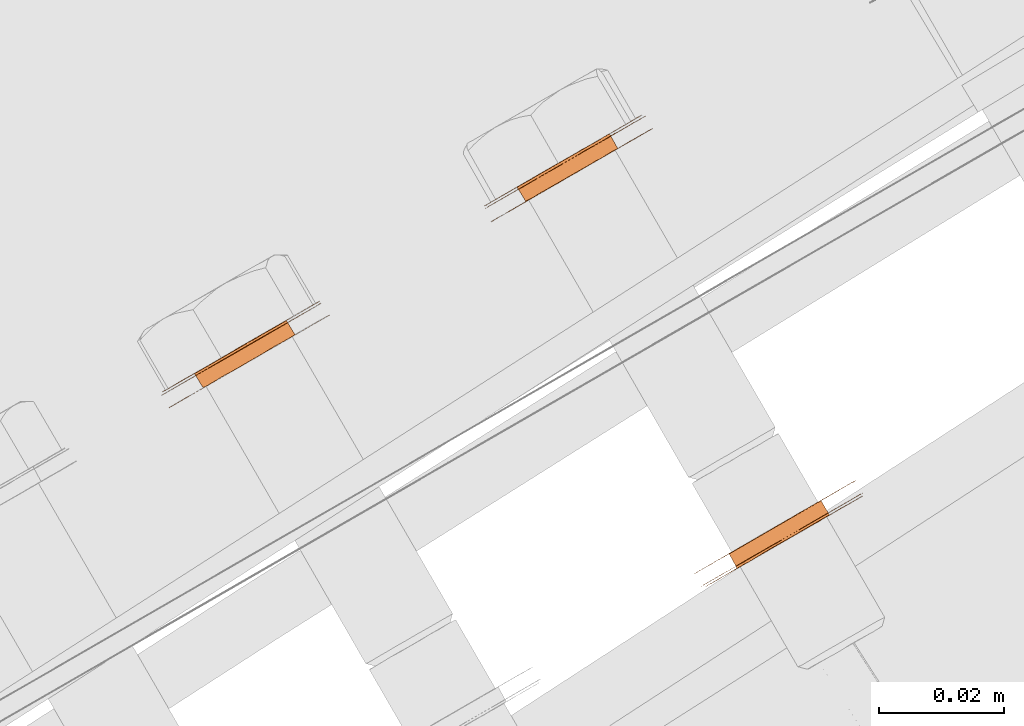
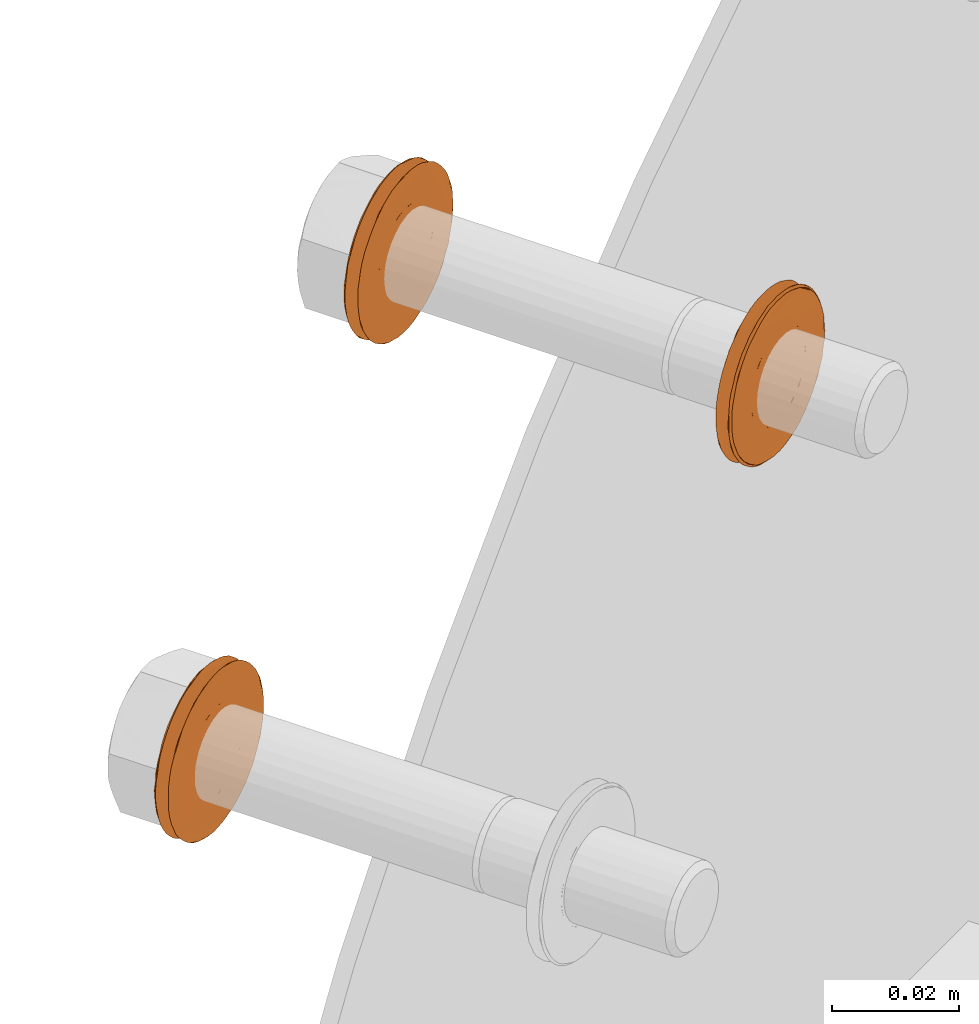
# One storey, part 107 of 126: 3 proxies.
"""IFC2X3 building model written with IfcOpenShell, lengths in millimetres."""

from ifc_helpers import new_model, si_unit, origin, origin_with_axes, place, context, project, spatial, faceted_brep, material, element, save


model = new_model("IFC2X3")

# Units and contexts
context_of_model_1 = context(None, 3, precision=0.1, world=origin())
context_of_model_2 = context(None, 3, precision=0.1, world=origin())
ifc_project = project(units=[si_unit("LENGTHUNIT", "METRE", prefix="MILLI"), si_unit("AREAUNIT", "SQUARE_METRE", prefix="CENTI"), si_unit("VOLUMEUNIT", "CUBIC_METRE", prefix="CENTI"), si_unit("MASSUNIT", "GRAM", prefix="KILO")], contexts=[context_of_model_1, context_of_model_2])

# Site, building, storey
site_placement = place(None, origin_with_axes())
site = spatial("IfcSite", under=ifc_project, at=site_placement, CompositionType="ELEMENT")
building_placement = place(site_placement, origin_with_axes())
building = spatial("IfcBuilding", under=site, at=building_placement, CompositionType="ELEMENT")
storey_placement = place(building_placement, origin_with_axes())
storey = spatial("IfcBuildingStorey", under=building, at=storey_placement, CompositionType="ELEMENT")

# Proxies
ifc_material = material(Name="STAHL")
proxy_1_placement = place(storey_placement, origin_with_axes())
element("IfcBuildingElementProxy", 1, at=proxy_1_placement, inside=storey, material=ifc_material, Name="profile", context=context_of_model_2, shape_type="Brep", body=[
    faceted_brep([(3703.7, 14806.2, 1165.8), (3705.0, 14803.9, 1165.8), (3705.3, 14804.1, 1167.0), (3704.0, 14806.4, 1167.0), (3703.2, 14806.0, 1164.7), (3704.6, 14803.6, 1164.7), (3702.7, 14805.7, 1163.7), (3704.0, 14803.3, 1163.7), (3702.0, 14805.3, 1162.8), (3703.3, 14802.9, 1162.8), (3692.4, 14799.7, 1175.6), (3693.7, 14797.4, 1175.6), (3692.9, 14796.9, 1174.8), (3691.6, 14799.2, 1174.8), (3693.3, 14800.2, 1176.2), (3694.6, 14797.9, 1176.2), (3694.2, 14800.8, 1176.8), (3695.6, 14798.4, 1176.8), (3695.2, 14801.3, 1177.1), (3696.6, 14799.0, 1177.1), (3696.3, 14802.0, 1177.3), (3697.6, 14799.6, 1177.3), (3697.3, 14802.6, 1177.3), (3698.7, 14800.2, 1177.3), (3698.4, 14803.2, 1177.1), (3699.7, 14800.8, 1177.1), (3699.4, 14803.7, 1176.8), (3700.7, 14801.4, 1176.8), (3700.3, 14804.3, 1176.2), (3701.7, 14802.0, 1176.2), (3701.2, 14804.8, 1175.6), (3702.5, 14802.5, 1175.6), (3702.0, 14805.3, 1174.8), (3703.3, 14802.9, 1174.8), (3702.7, 14805.7, 1173.9), (3704.0, 14803.3, 1173.9), (3703.2, 14806.0, 1172.9), (3704.6, 14803.6, 1172.9), (3703.7, 14806.2, 1171.8), (3705.0, 14803.9, 1171.8), (3704.0, 14806.4, 1170.6), (3705.3, 14804.1, 1170.6), (3704.1, 14806.5, 1169.4), (3705.5, 14804.2, 1169.4), (3704.1, 14806.5, 1168.2), (3705.5, 14804.2, 1168.2), (3685.2, 14792.4, 1168.0), (3685.2, 14792.4, 1169.6), (3685.3, 14792.5, 1171.1), (3685.6, 14792.7, 1172.7), (3686.0, 14792.9, 1174.2), (3686.6, 14793.2, 1175.6), (3687.2, 14793.6, 1177.0), (3688.0, 14794.1, 1178.2), (3689.0, 14794.6, 1179.4), (3690.0, 14795.2, 1180.4), (3691.1, 14795.8, 1181.4), (3692.2, 14796.5, 1182.2), (3693.5, 14797.2, 1182.8), (3694.8, 14798.0, 1183.3), (3696.1, 14798.7, 1183.6), (3697.5, 14799.5, 1183.8), (3698.8, 14800.3, 1183.8), (3700.2, 14801.1, 1183.6), (3701.5, 14801.9, 1183.3), (3702.8, 14802.6, 1182.8), (3704.0, 14803.3, 1182.2), (3705.2, 14804.0, 1181.4), (3706.3, 14804.6, 1180.4), (3707.3, 14805.2, 1179.4), (3708.2, 14805.7, 1178.2), (3709.0, 14806.2, 1177.0), (3709.7, 14806.6, 1175.6), (3710.3, 14806.9, 1174.2), (3710.7, 14807.2, 1172.7), (3711.0, 14807.3, 1171.1), (3709.8, 14809.3, 1171.1), (3709.5, 14809.2, 1172.7), (3709.1, 14808.9, 1174.2), (3708.6, 14808.6, 1175.6), (3707.9, 14808.2, 1177.0), (3707.1, 14807.7, 1178.2), (3706.2, 14807.2, 1179.4), (3705.2, 14806.6, 1180.4), (3704.1, 14806.0, 1181.4), (3702.9, 14805.3, 1182.2), (3701.6, 14804.6, 1182.8), (3700.4, 14803.8, 1183.3), (3699.0, 14803.1, 1183.6), (3697.7, 14802.3, 1183.8), (3696.3, 14801.5, 1183.8), (3695.0, 14800.7, 1183.6), (3693.6, 14800.0, 1183.3), (3692.3, 14799.2, 1182.8), (3691.1, 14798.5, 1182.2), (3689.9, 14797.8, 1181.4), (3688.8, 14797.2, 1180.4), (3687.8, 14796.6, 1179.4), (3686.9, 14796.1, 1178.2), (3686.1, 14795.6, 1177.0), (3685.4, 14795.2, 1175.6), (3684.9, 14794.9, 1174.2), (3684.4, 14794.7, 1172.7), (3684.2, 14794.5, 1171.1), (3684.0, 14794.4, 1169.6), (3684.0, 14794.4, 1168.0), (3684.2, 14794.5, 1166.4), (3684.4, 14794.7, 1164.9), (3684.9, 14794.9, 1163.4), (3685.4, 14795.2, 1162.0), (3686.1, 14795.6, 1160.6), (3686.9, 14796.1, 1159.3), (3687.8, 14796.6, 1158.2), (3688.8, 14797.2, 1157.1), (3689.9, 14797.8, 1156.2), (3691.1, 14798.5, 1155.4), (3692.3, 14799.2, 1154.8), (3693.6, 14800.0, 1154.3), (3695.0, 14800.7, 1154.0), (3696.3, 14801.5, 1153.8), (3697.7, 14802.3, 1153.8), (3699.0, 14803.1, 1154.0), (3700.4, 14803.8, 1154.3), (3701.6, 14804.6, 1154.8), (3702.9, 14805.3, 1155.4), (3704.1, 14806.0, 1156.2), (3705.2, 14806.6, 1157.1), (3706.2, 14807.2, 1158.2), (3707.1, 14807.7, 1159.3), (3707.9, 14808.2, 1160.6), (3708.6, 14808.6, 1162.0), (3709.1, 14808.9, 1163.4), (3709.5, 14809.2, 1164.9), (3709.8, 14809.3, 1166.4), (3710.0, 14809.4, 1168.0), (3710.0, 14809.4, 1169.6), (3711.1, 14807.4, 1169.6), (3711.1, 14807.4, 1168.0), (3711.0, 14807.3, 1166.4), (3710.7, 14807.2, 1164.9), (3710.3, 14806.9, 1163.4), (3709.7, 14806.6, 1162.0), (3709.0, 14806.2, 1160.6), (3708.2, 14805.7, 1159.3), (3707.3, 14805.2, 1158.2), (3706.3, 14804.6, 1157.1), (3705.2, 14804.0, 1156.2), (3704.0, 14803.3, 1155.4), (3702.8, 14802.6, 1154.8), (3701.5, 14801.9, 1154.3), (3700.2, 14801.1, 1154.0), (3698.8, 14800.3, 1153.8), (3697.5, 14799.5, 1153.8), (3696.1, 14798.7, 1154.0), (3694.8, 14798.0, 1154.3), (3693.5, 14797.2, 1154.8), (3692.2, 14796.5, 1155.4), (3691.1, 14795.8, 1156.2), (3690.0, 14795.2, 1157.1), (3689.0, 14794.6, 1158.2), (3688.0, 14794.1, 1159.3), (3687.2, 14793.6, 1160.6), (3686.6, 14793.2, 1162.0), (3686.0, 14792.9, 1163.4), (3685.6, 14792.7, 1164.9), (3685.3, 14792.5, 1166.4), (3695.8, 14801.7, 1154.2), (3697.1, 14802.5, 1154.2), (3698.5, 14803.2, 1154.3), (3699.8, 14804.0, 1154.6), (3701.1, 14804.8, 1155.1), (3702.4, 14805.5, 1155.7), (3703.6, 14806.2, 1156.5), (3704.7, 14806.8, 1157.4), (3705.7, 14807.4, 1158.5), (3706.6, 14807.9, 1159.6), (3707.4, 14808.4, 1160.9), (3708.1, 14808.8, 1162.3), (3708.7, 14809.1, 1163.8), (3709.1, 14809.3, 1165.3), (3709.3, 14809.5, 1166.8), (3709.4, 14809.6, 1168.4), (3709.4, 14809.5, 1170.0), (3709.2, 14809.4, 1171.5), (3708.9, 14809.2, 1173.1), (3708.4, 14809.0, 1174.6), (3707.8, 14808.6, 1176.0), (3707.1, 14808.2, 1177.3), (3706.2, 14807.7, 1178.5), (3705.2, 14807.1, 1179.7), (3704.2, 14806.5, 1180.6), (3703.0, 14805.8, 1181.5), (3701.8, 14805.1, 1182.2), (3700.5, 14804.4, 1182.7), (3699.2, 14803.6, 1183.1), (3697.8, 14802.8, 1183.3), (3696.4, 14802.1, 1183.4), (3695.1, 14801.3, 1183.3), (3693.7, 14800.5, 1183.0), (3692.4, 14799.7, 1182.5), (3691.2, 14799.0, 1181.9), (3690.0, 14798.3, 1181.1), (3688.9, 14797.7, 1180.2), (3687.8, 14797.1, 1179.1), (3686.9, 14796.6, 1177.9), (3686.1, 14796.1, 1176.7), (3685.5, 14795.7, 1175.3), (3684.9, 14795.4, 1173.8), (3684.5, 14795.2, 1172.3), (3684.3, 14795.0, 1170.8), (3684.1, 14795.0, 1169.2), (3684.2, 14795.0, 1167.6), (3684.4, 14795.1, 1166.0), (3684.7, 14795.3, 1164.5), (3685.2, 14795.5, 1163.0), (3685.8, 14795.9, 1161.6), (3686.5, 14796.3, 1160.3), (3687.4, 14796.8, 1159.0), (3688.3, 14797.4, 1157.9), (3689.4, 14798.0, 1156.9), (3690.6, 14798.7, 1156.1), (3691.8, 14799.4, 1155.4), (3693.1, 14800.1, 1154.8), (3694.4, 14800.9, 1154.5), (3697.3, 14802.6, 1160.3), (3698.4, 14803.2, 1160.5), (3699.4, 14803.7, 1160.8), (3700.3, 14804.3, 1161.3), (3701.2, 14804.8, 1162.0), (3690.9, 14798.9, 1173.9), (3690.3, 14798.5, 1172.9), (3689.9, 14798.3, 1171.8), (3689.6, 14798.1, 1170.6), (3689.4, 14798.0, 1169.4), (3689.4, 14798.0, 1168.2), (3689.6, 14798.1, 1167.0), (3689.9, 14798.3, 1165.8), (3690.3, 14798.5, 1164.7), (3690.9, 14798.9, 1163.7), (3691.6, 14799.2, 1162.8), (3692.4, 14799.7, 1162.0), (3693.3, 14800.2, 1161.3), (3694.2, 14800.8, 1160.8), (3695.2, 14801.3, 1160.5), (3696.3, 14802.0, 1160.3), (3692.2, 14796.5, 1173.9), (3702.5, 14802.5, 1162.0), (3701.7, 14802.0, 1161.3), (3700.7, 14801.4, 1160.8), (3699.7, 14800.8, 1160.5), (3698.7, 14800.2, 1160.3), (3697.6, 14799.6, 1160.3), (3696.6, 14799.0, 1160.5), (3695.6, 14798.4, 1160.8), (3694.6, 14797.9, 1161.3), (3693.7, 14797.4, 1162.0), (3692.9, 14796.9, 1162.8), (3692.2, 14796.5, 1163.7), (3691.7, 14796.2, 1164.7), (3691.2, 14795.9, 1165.8), (3690.9, 14795.8, 1167.0), (3690.8, 14795.7, 1168.2), (3690.8, 14795.7, 1169.4), (3690.9, 14795.8, 1170.6), (3691.2, 14795.9, 1171.8), (3691.7, 14796.2, 1172.9)], [[[0, 1, 2, 3]], [[4, 5, 1, 0]], [[6, 7, 5, 4]], [[6, 8, 9, 7]], [[10, 11, 12, 13]], [[14, 15, 11, 10]], [[16, 17, 15, 14]], [[18, 19, 17, 16]], [[20, 21, 19, 18]], [[22, 23, 21, 20]], [[24, 25, 23, 22]], [[26, 27, 25, 24]], [[28, 29, 27, 26]], [[30, 31, 29, 28]], [[32, 33, 31, 30]], [[34, 35, 33, 32]], [[36, 37, 35, 34]], [[38, 39, 37, 36]], [[40, 41, 39, 38]], [[42, 43, 41, 40]], [[44, 45, 43, 42]], [[3, 2, 45, 44]], [[46, 47, 48, 49, 50, 51, 52, 53, 54, 55, 56, 57, 58, 59, 60, 61, 62, 63, 64, 65, 66, 67, 68, 69, 70, 71, 72, 73, 74, 75, 76, 77, 78, 79, 80, 81, 82, 83, 84, 85, 86, 87, 88, 89, 90, 91, 92, 93, 94, 95, 96, 97, 98, 99, 100, 101, 102, 103, 104, 105, 106, 107, 108, 109, 110, 111, 112, 113, 114, 115, 116, 117, 118, 119, 120, 121, 122, 123, 124, 125, 126, 127, 128, 129, 130, 131, 132, 133, 134, 135, 76, 75, 136, 137, 138, 139, 140, 141, 142, 143, 144, 145, 146, 147, 148, 149, 150, 151, 152, 153, 154, 155, 156, 157, 158, 159, 160, 161, 162, 163, 164, 165]], [[105, 104, 103, 102, 101, 100, 99, 98, 97, 96, 95, 94, 93, 92, 91, 90, 89, 88, 87, 86, 85, 84, 83, 82, 81, 80, 79, 78, 77, 76, 135, 134, 133, 132, 131, 130, 129, 128, 127, 126, 125, 124, 123, 122, 121, 120, 119, 166, 167, 168, 169, 170, 171, 172, 173, 174, 175, 176, 177, 178, 179, 180, 181, 182, 183, 184, 185, 186, 187, 188, 189, 190, 191, 192, 193, 194, 195, 196, 197, 198, 199, 200, 201, 202, 203, 204, 205, 206, 207, 208, 209, 210, 211, 212, 213, 214, 215, 216, 217, 218, 219, 220, 221, 222, 223, 166, 119, 118, 117, 116, 115, 114, 113, 112, 111, 110, 109, 108, 107, 106]], [[210, 209, 208, 207, 206, 205, 204, 203, 202, 201, 200, 199, 198, 197, 196, 195, 194, 193, 192, 191, 190, 189, 188, 187, 186, 185, 184, 183, 182, 181, 180, 179, 178, 177, 176, 175, 174, 173, 172, 171, 170, 169, 168, 167, 224, 225, 226, 227, 228, 8, 6, 4, 0, 3, 44, 42, 40, 38, 36, 34, 32, 30, 28, 26, 24, 22, 20, 18, 16, 14, 10, 13, 229, 230, 231, 232, 233, 234, 235, 236, 237, 238, 239, 240, 241, 242, 243, 244, 224, 167, 166, 223, 222, 221, 220, 219, 218, 217, 216, 215, 214, 213, 212, 211]], [[229, 13, 12, 245]], [[228, 246, 9, 8]], [[228, 227, 247, 246]], [[227, 226, 248, 247]], [[226, 225, 249, 248]], [[225, 224, 250, 249]], [[224, 244, 251, 250]], [[244, 243, 252, 251]], [[243, 242, 253, 252]], [[242, 241, 254, 253]], [[241, 240, 255, 254]], [[240, 239, 256, 255]], [[239, 238, 257, 256]], [[238, 237, 258, 257]], [[237, 236, 259, 258]], [[236, 235, 260, 259]], [[235, 234, 261, 260]], [[234, 233, 262, 261]], [[233, 232, 263, 262]], [[232, 231, 264, 263]], [[231, 230, 265, 264]], [[230, 229, 245, 265]], [[47, 46, 165, 164, 163, 162, 161, 160, 159, 158, 157, 156, 155, 154, 153, 152, 151, 251, 252, 253, 254, 255, 256, 257, 258, 259, 260, 261, 262, 263, 264, 265, 245, 12, 11, 15, 17, 19, 21, 23, 25, 27, 29, 31, 33, 35, 37, 39, 41, 43, 45, 2, 1, 5, 7, 9, 246, 247, 248, 249, 250, 251, 151, 150, 149, 148, 147, 146, 145, 144, 143, 142, 141, 140, 139, 138, 137, 136, 75, 74, 73, 72, 71, 70, 69, 68, 67, 66, 65, 64, 63, 62, 61, 60, 59, 58, 57, 56, 55, 54, 53, 52, 51, 50, 49, 48]]]),
])
proxy_2_placement = place(storey_placement, origin_with_axes())
element("IfcBuildingElementProxy", 2, at=proxy_2_placement, inside=storey, material=ifc_material, Name="profile", context=context_of_model_2, shape_type="Brep", body=[
    faceted_brep([(3785.8, 14772.4, 1220.3), (3784.5, 14774.7, 1220.3), (3783.4, 14774.1, 1220.0), (3784.8, 14771.8, 1220.0), (3786.8, 14772.9, 1220.7), (3785.4, 14775.3, 1220.7), (3787.7, 14773.4, 1221.3), (3786.3, 14775.8, 1221.3), (3778.7, 14768.2, 1234.7), (3777.3, 14770.6, 1234.7), (3778.2, 14771.1, 1235.5), (3779.5, 14768.7, 1235.5), (3778.0, 14767.8, 1233.8), (3776.6, 14770.2, 1233.8), (3777.3, 14767.5, 1232.9), (3776.0, 14769.8, 1232.9), (3776.9, 14767.2, 1231.8), (3775.5, 14769.5, 1231.8), (3776.5, 14767.0, 1230.6), (3775.2, 14769.3, 1230.6), (3776.3, 14766.9, 1229.5), (3775.0, 14769.2, 1229.5), (3776.2, 14766.8, 1228.2), (3774.9, 14769.2, 1228.2), (3776.3, 14766.9, 1227.0), (3775.0, 14769.2, 1227.0), (3776.6, 14767.0, 1225.9), (3775.2, 14769.4, 1225.9), (3777.0, 14767.3, 1224.7), (3775.6, 14769.6, 1224.7), (3777.5, 14767.6, 1223.7), (3776.1, 14769.9, 1223.7), (3778.1, 14767.9, 1222.7), (3776.8, 14770.3, 1222.7), (3778.9, 14768.4, 1221.9), (3777.5, 14770.7, 1221.9), (3779.7, 14768.9, 1221.2), (3778.4, 14771.2, 1221.2), (3780.7, 14769.4, 1220.6), (3779.3, 14771.7, 1220.6), (3781.7, 14770.0, 1220.2), (3780.3, 14772.3, 1220.2), (3782.7, 14770.6, 1220.0), (3781.3, 14772.9, 1220.0), (3783.7, 14771.2, 1219.9), (3782.4, 14773.5, 1219.9), (3770.4, 14763.9, 1229.0), (3770.6, 14764.0, 1230.5), (3770.8, 14764.2, 1232.1), (3771.2, 14764.4, 1233.6), (3771.8, 14764.7, 1235.0), (3772.4, 14765.1, 1236.4), (3773.2, 14765.5, 1237.7), (3774.1, 14766.1, 1238.9), (3775.1, 14766.6, 1239.9), (3776.2, 14767.3, 1240.9), (3777.4, 14767.9, 1241.7), (3778.6, 14768.7, 1242.3), (3779.9, 14769.4, 1242.8), (3781.2, 14770.2, 1243.2), (3782.6, 14770.9, 1243.4), (3783.9, 14771.7, 1243.4), (3785.3, 14772.5, 1243.2), (3786.6, 14773.3, 1242.9), (3787.9, 14774.0, 1242.5), (3789.2, 14774.8, 1241.8), (3790.3, 14775.4, 1241.1), (3791.4, 14776.1, 1240.2), (3792.5, 14776.7, 1239.1), (3793.4, 14777.2, 1238.0), (3794.2, 14777.7, 1236.7), (3794.9, 14778.1, 1235.4), (3795.5, 14778.4, 1234.0), (3795.9, 14778.7, 1232.5), (3796.2, 14778.8, 1230.9), (3796.4, 14778.9, 1229.4), (3796.4, 14778.9, 1227.8), (3796.3, 14778.9, 1226.2), (3796.0, 14778.7, 1224.7), (3795.6, 14778.5, 1223.2), (3795.1, 14778.2, 1221.8), (3794.4, 14777.8, 1220.4), (3793.6, 14777.3, 1219.1), (3792.7, 14776.8, 1217.9), (3791.7, 14776.2, 1216.9), (3790.6, 14775.6, 1215.9), (3789.5, 14774.9, 1215.1), (3788.2, 14774.2, 1214.5), (3786.9, 14773.5, 1214.0), (3785.6, 14772.7, 1213.6), (3784.3, 14771.9, 1213.4), (3782.9, 14771.1, 1213.4), (3781.5, 14770.4, 1213.5), (3780.2, 14769.6, 1213.9), (3778.9, 14768.8, 1214.3), (3777.7, 14768.1, 1214.9), (3776.5, 14770.1, 1214.9), (3777.8, 14770.8, 1214.3), (3779.1, 14771.6, 1213.9), (3780.4, 14772.3, 1213.5), (3781.7, 14773.1, 1213.4), (3783.1, 14773.9, 1213.4), (3784.5, 14774.7, 1213.6), (3785.8, 14775.5, 1214.0), (3787.1, 14776.2, 1214.5), (3788.3, 14776.9, 1215.1), (3789.5, 14777.6, 1215.9), (3790.6, 14778.2, 1216.9), (3791.6, 14778.8, 1217.9), (3792.5, 14779.3, 1219.1), (3793.2, 14779.8, 1220.4), (3793.9, 14780.2, 1221.8), (3794.4, 14780.5, 1223.2), (3794.8, 14780.7, 1224.7), (3795.1, 14780.8, 1226.2), (3795.2, 14780.9, 1227.8), (3795.2, 14780.9, 1229.4), (3795.1, 14780.8, 1230.9), (3794.8, 14780.6, 1232.5), (3794.3, 14780.4, 1234.0), (3793.8, 14780.1, 1235.4), (3793.1, 14779.7, 1236.7), (3792.2, 14779.2, 1238.0), (3791.3, 14778.7, 1239.1), (3790.3, 14778.1, 1240.2), (3789.2, 14777.4, 1241.1), (3788.0, 14776.7, 1241.8), (3786.8, 14776.0, 1242.5), (3785.5, 14775.3, 1242.9), (3784.1, 14774.5, 1243.2), (3782.8, 14773.7, 1243.4), (3781.4, 14772.9, 1243.4), (3780.1, 14772.2, 1243.2), (3778.7, 14771.4, 1242.8), (3777.4, 14770.6, 1242.3), (3776.2, 14769.9, 1241.7), (3775.0, 14769.3, 1240.9), (3774.0, 14768.6, 1239.9), (3773.0, 14768.1, 1238.9), (3772.1, 14767.5, 1237.7), (3771.3, 14767.1, 1236.4), (3770.6, 14766.7, 1235.0), (3770.1, 14766.4, 1233.6), (3769.7, 14766.2, 1232.1), (3769.4, 14766.0, 1230.5), (3769.3, 14765.9, 1229.0), (3769.3, 14765.9, 1227.4), (3769.5, 14766.0, 1225.9), (3769.8, 14766.2, 1224.3), (3770.2, 14766.5, 1222.8), (3770.8, 14766.8, 1221.4), (3771.5, 14767.2, 1220.1), (3772.3, 14767.7, 1218.8), (3773.2, 14768.2, 1217.6), (3774.2, 14768.8, 1216.6), (3775.3, 14769.4, 1215.7), (3776.5, 14767.4, 1215.7), (3775.4, 14766.8, 1216.6), (3774.3, 14766.2, 1217.6), (3773.4, 14765.7, 1218.8), (3772.6, 14765.2, 1220.1), (3771.9, 14764.8, 1221.4), (3771.3, 14764.5, 1222.8), (3770.9, 14764.2, 1224.3), (3770.6, 14764.0, 1225.9), (3770.4, 14764.0, 1227.4), (3771.0, 14763.8, 1228.5), (3771.0, 14763.8, 1230.1), (3771.3, 14764.0, 1231.6), (3771.7, 14764.2, 1233.1), (3772.2, 14764.5, 1234.6), (3772.8, 14764.9, 1236.0), (3773.6, 14765.3, 1237.3), (3774.5, 14765.8, 1238.5), (3775.5, 14766.4, 1239.6), (3776.6, 14767.0, 1240.5), (3777.8, 14767.7, 1241.3), (3779.0, 14768.4, 1242.0), (3780.3, 14769.2, 1242.5), (3781.6, 14770.0, 1242.8), (3783.0, 14770.7, 1243.0), (3784.4, 14771.5, 1243.0), (3785.7, 14772.3, 1242.8), (3787.1, 14773.1, 1242.4), (3788.4, 14773.8, 1241.9), (3789.6, 14774.6, 1241.2), (3790.8, 14775.2, 1240.4), (3791.9, 14775.9, 1239.5), (3792.8, 14776.4, 1238.4), (3793.7, 14776.9, 1237.2), (3794.5, 14777.4, 1235.8), (3795.1, 14777.7, 1234.4), (3795.6, 14778.0, 1233.0), (3796.0, 14778.2, 1231.4), (3796.2, 14778.4, 1229.9), (3796.3, 14778.4, 1228.3), (3796.2, 14778.3, 1226.7), (3795.9, 14778.2, 1225.2), (3795.6, 14778.0, 1223.6), (3795.0, 14777.7, 1222.2), (3794.4, 14777.3, 1220.8), (3793.6, 14776.9, 1219.5), (3792.7, 14776.4, 1218.3), (3791.7, 14775.8, 1217.2), (3790.6, 14775.1, 1216.3), (3789.5, 14774.5, 1215.4), (3788.2, 14773.7, 1214.8), (3786.9, 14773.0, 1214.3), (3785.6, 14772.2, 1214.0), (3784.2, 14771.4, 1213.8), (3782.8, 14770.6, 1213.8), (3781.5, 14769.9, 1214.0), (3780.1, 14769.1, 1214.4), (3778.8, 14768.3, 1214.9), (3777.6, 14767.6, 1215.5), (3776.4, 14767.0, 1216.4), (3775.4, 14766.3, 1217.3), (3774.4, 14765.8, 1218.4), (3773.5, 14765.2, 1219.6), (3772.7, 14764.8, 1221.0), (3772.1, 14764.4, 1222.4), (3771.6, 14764.2, 1223.8), (3771.2, 14763.9, 1225.4), (3771.0, 14763.8, 1226.9), (3790.7, 14775.2, 1226.1), (3790.4, 14775.0, 1225.0), (3789.9, 14774.7, 1223.9), (3789.3, 14774.3, 1222.9), (3788.5, 14773.9, 1222.1), (3780.4, 14769.3, 1236.1), (3781.4, 14769.8, 1236.5), (3782.4, 14770.4, 1236.8), (3783.5, 14771.0, 1236.9), (3784.5, 14771.6, 1236.8), (3785.6, 14772.2, 1236.6), (3786.5, 14772.8, 1236.2), (3787.5, 14773.3, 1235.6), (3788.3, 14773.8, 1234.9), (3789.1, 14774.2, 1234.1), (3789.7, 14774.6, 1233.1), (3790.2, 14774.9, 1232.1), (3790.6, 14775.1, 1230.9), (3790.9, 14775.3, 1229.8), (3791.0, 14775.3, 1228.5), (3790.9, 14775.3, 1227.3), (3781.1, 14772.7, 1236.8), (3782.1, 14773.4, 1236.9), (3780.1, 14772.2, 1236.5), (3779.1, 14771.6, 1236.1), (3787.2, 14776.3, 1222.1), (3787.9, 14776.7, 1222.9), (3788.5, 14777.0, 1223.9), (3789.0, 14777.3, 1225.0), (3789.4, 14777.5, 1226.1), (3789.6, 14777.6, 1227.3), (3789.6, 14777.7, 1228.5), (3789.5, 14777.6, 1229.8), (3789.3, 14777.5, 1230.9), (3788.9, 14777.3, 1232.1), (3788.4, 14777.0, 1233.1), (3787.7, 14776.6, 1234.1), (3787.0, 14776.2, 1234.9), (3786.1, 14775.7, 1235.6), (3785.2, 14775.1, 1236.2), (3784.2, 14774.6, 1236.6), (3783.2, 14774.0, 1236.8)], [[[0, 1, 2, 3]], [[4, 5, 1, 0]], [[4, 6, 7, 5]], [[8, 9, 10, 11]], [[12, 13, 9, 8]], [[14, 15, 13, 12]], [[16, 17, 15, 14]], [[18, 19, 17, 16]], [[20, 21, 19, 18]], [[22, 23, 21, 20]], [[24, 25, 23, 22]], [[26, 27, 25, 24]], [[28, 29, 27, 26]], [[30, 31, 29, 28]], [[32, 33, 31, 30]], [[34, 35, 33, 32]], [[36, 37, 35, 34]], [[38, 39, 37, 36]], [[40, 41, 39, 38]], [[42, 43, 41, 40]], [[44, 45, 43, 42]], [[3, 2, 45, 44]], [[46, 47, 48, 49, 50, 51, 52, 53, 54, 55, 56, 57, 58, 59, 60, 61, 62, 63, 64, 65, 66, 67, 68, 69, 70, 71, 72, 73, 74, 75, 76, 77, 78, 79, 80, 81, 82, 83, 84, 85, 86, 87, 88, 89, 90, 91, 92, 93, 94, 95, 96, 97, 98, 99, 100, 101, 102, 103, 104, 105, 106, 107, 108, 109, 110, 111, 112, 113, 114, 115, 116, 117, 118, 119, 120, 121, 122, 123, 124, 125, 126, 127, 128, 129, 130, 131, 132, 133, 134, 135, 136, 137, 138, 139, 140, 141, 142, 143, 144, 145, 146, 147, 148, 149, 150, 151, 152, 153, 154, 155, 96, 95, 156, 157, 158, 159, 160, 161, 162, 163, 164, 165]], [[166, 167, 168, 169, 170, 171, 172, 173, 174, 175, 176, 177, 178, 179, 180, 181, 182, 183, 184, 185, 186, 187, 188, 189, 190, 191, 192, 193, 194, 195, 196, 77, 76, 75, 74, 73, 72, 71, 70, 69, 68, 67, 66, 65, 64, 63, 62, 61, 60, 59, 58, 57, 56, 55, 54, 53, 52, 51, 50, 49, 48, 47, 46, 165, 164, 163, 162, 161, 160, 159, 158, 157, 156, 95, 94, 93, 92, 91, 90, 89, 88, 87, 86, 85, 84, 83, 82, 81, 80, 79, 78, 77, 196, 197, 198, 199, 200, 201, 202, 203, 204, 205, 206, 207, 208, 209, 210, 211, 212, 213, 214, 215, 216, 217, 218, 219, 220, 221, 222, 223]], [[166, 223, 222, 221, 220, 219, 218, 217, 216, 215, 214, 213, 212, 211, 210, 209, 208, 207, 206, 205, 204, 203, 202, 201, 200, 199, 198, 197, 224, 225, 226, 227, 228, 6, 4, 0, 3, 44, 42, 40, 38, 36, 34, 32, 30, 28, 26, 24, 22, 20, 18, 16, 14, 12, 8, 11, 229, 230, 231, 232, 233, 234, 235, 236, 237, 238, 239, 240, 241, 242, 243, 244, 224, 197, 196, 195, 194, 193, 192, 191, 190, 189, 188, 187, 186, 185, 184, 183, 182, 181, 180, 179, 178, 177, 176, 175, 174, 173, 172, 171, 170, 169, 168, 167]], [[231, 245, 246, 232]], [[230, 247, 245, 231]], [[229, 248, 247, 230]], [[228, 249, 7, 6]], [[11, 10, 248, 229]], [[227, 250, 249, 228]], [[226, 251, 250, 227]], [[225, 252, 251, 226]], [[224, 253, 252, 225]], [[244, 254, 253, 224]], [[243, 255, 254, 244]], [[242, 256, 255, 243]], [[241, 257, 256, 242]], [[240, 258, 257, 241]], [[239, 259, 258, 240]], [[238, 260, 259, 239]], [[237, 261, 260, 238]], [[236, 262, 261, 237]], [[235, 263, 262, 236]], [[234, 264, 263, 235]], [[233, 265, 264, 234]], [[232, 246, 265, 233]], [[145, 144, 143, 142, 141, 140, 139, 138, 137, 136, 135, 134, 133, 132, 131, 130, 129, 128, 127, 126, 125, 124, 123, 122, 121, 120, 119, 118, 117, 116, 115, 114, 113, 254, 255, 256, 257, 258, 259, 260, 261, 262, 263, 264, 265, 246, 245, 247, 248, 10, 9, 13, 15, 17, 19, 21, 23, 25, 27, 29, 31, 33, 35, 37, 39, 41, 43, 45, 2, 1, 5, 7, 249, 250, 251, 252, 253, 254, 113, 112, 111, 110, 109, 108, 107, 106, 105, 104, 103, 102, 101, 100, 99, 98, 97, 96, 155, 154, 153, 152, 151, 150, 149, 148, 147, 146]]]),
])
proxy_3_placement = place(storey_placement, origin_with_axes())
element("IfcBuildingElementProxy", 3, at=proxy_3_placement, inside=storey, material=ifc_material, Name="profile", context=context_of_model_2, shape_type="Brep", body=[
    faceted_brep([(3752.5, 14834.4, 1221.3), (3753.8, 14832.1, 1221.3), (3754.7, 14832.6, 1222.1), (3753.3, 14834.9, 1222.1), (3744.3, 14829.7, 1235.5), (3745.2, 14830.2, 1236.1), (3746.6, 14827.9, 1236.1), (3745.7, 14827.4, 1235.5), (3746.2, 14830.8, 1236.5), (3747.6, 14828.4, 1236.5), (3747.2, 14831.4, 1236.8), (3748.6, 14829.0, 1236.8), (3748.3, 14832.0, 1236.9), (3749.6, 14829.6, 1236.9), (3749.3, 14832.6, 1236.8), (3750.7, 14830.2, 1236.8), (3750.4, 14833.2, 1236.6), (3751.7, 14830.8, 1236.6), (3751.3, 14833.8, 1236.2), (3752.7, 14831.4, 1236.2), (3752.3, 14834.3, 1235.6), (3753.6, 14832.0, 1235.6), (3753.1, 14834.8, 1234.9), (3754.5, 14832.4, 1234.9), (3753.9, 14835.2, 1234.1), (3755.2, 14832.9, 1234.1), (3754.5, 14835.6, 1233.1), (3755.9, 14833.3, 1233.1), (3755.0, 14835.9, 1232.1), (3756.4, 14833.6, 1232.1), (3755.4, 14836.1, 1230.9), (3756.8, 14833.8, 1230.9), (3755.7, 14836.3, 1229.8), (3757.0, 14833.9, 1229.8), (3755.8, 14836.3, 1228.5), (3757.1, 14834.0, 1228.5), (3755.7, 14836.3, 1227.3), (3757.1, 14833.9, 1227.3), (3755.5, 14836.2, 1226.1), (3756.9, 14833.8, 1226.1), (3755.2, 14836.0, 1225.0), (3756.5, 14833.6, 1225.0), (3754.7, 14835.7, 1223.9), (3756.0, 14833.3, 1223.9), (3754.1, 14835.3, 1222.9), (3755.4, 14833.0, 1222.9), (3736.8, 14822.2, 1229.0), (3736.9, 14822.3, 1230.5), (3737.2, 14822.4, 1232.1), (3737.6, 14822.7, 1233.6), (3738.1, 14823.0, 1235.0), (3738.8, 14823.4, 1236.4), (3739.6, 14823.8, 1237.7), (3740.5, 14824.3, 1238.9), (3741.5, 14824.9, 1239.9), (3742.5, 14825.6, 1240.9), (3743.7, 14826.2, 1241.7), (3744.9, 14826.9, 1242.3), (3746.2, 14827.7, 1242.8), (3747.6, 14828.4, 1243.2), (3748.9, 14829.2, 1243.4), (3750.3, 14830.0, 1243.4), (3751.6, 14830.8, 1243.2), (3753.0, 14831.6, 1242.9), (3754.3, 14832.3, 1242.5), (3755.5, 14833.0, 1241.8), (3756.7, 14833.7, 1241.1), (3757.8, 14834.4, 1240.2), (3758.8, 14835.0, 1239.1), (3759.7, 14835.5, 1238.0), (3760.6, 14836.0, 1236.7), (3761.3, 14836.4, 1235.4), (3761.8, 14836.7, 1234.0), (3762.3, 14836.9, 1232.5), (3762.6, 14837.1, 1230.9), (3762.7, 14837.2, 1229.4), (3762.7, 14837.2, 1227.8), (3762.6, 14837.1, 1226.2), (3762.3, 14837.0, 1224.7), (3761.5, 14839.1, 1226.2), (3761.6, 14839.2, 1227.8), (3761.6, 14839.2, 1229.4), (3761.4, 14839.1, 1230.9), (3761.1, 14838.9, 1232.5), (3760.7, 14838.7, 1234.0), (3760.1, 14838.3, 1235.4), (3759.4, 14837.9, 1236.7), (3758.6, 14837.5, 1238.0), (3757.7, 14836.9, 1239.1), (3756.6, 14836.4, 1240.2), (3755.5, 14835.7, 1241.1), (3754.4, 14835.0, 1241.8), (3753.1, 14834.3, 1242.5), (3751.8, 14833.6, 1242.9), (3750.5, 14832.8, 1243.2), (3749.1, 14832.0, 1243.4), (3747.8, 14831.2, 1243.4), (3746.4, 14830.4, 1243.2), (3745.1, 14829.7, 1242.8), (3743.8, 14828.9, 1242.3), (3742.6, 14828.2, 1241.7), (3741.4, 14827.5, 1240.9), (3740.3, 14826.9, 1239.9), (3739.3, 14826.3, 1238.9), (3738.4, 14825.8, 1237.7), (3737.6, 14825.4, 1236.4), (3737.0, 14825.0, 1235.0), (3736.4, 14824.7, 1233.6), (3736.0, 14824.4, 1232.1), (3735.8, 14824.3, 1230.5), (3735.6, 14824.2, 1229.0), (3735.6, 14824.2, 1227.4), (3735.8, 14824.3, 1225.9), (3736.1, 14824.5, 1224.3), (3736.5, 14824.7, 1222.8), (3737.1, 14825.1, 1221.4), (3737.8, 14825.5, 1220.1), (3738.6, 14825.9, 1218.8), (3739.5, 14826.5, 1217.6), (3740.6, 14827.1, 1216.6), (3741.7, 14827.7, 1215.7), (3742.9, 14828.4, 1214.9), (3744.1, 14829.1, 1214.3), (3745.4, 14829.9, 1213.9), (3746.7, 14830.6, 1213.5), (3748.1, 14831.4, 1213.4), (3749.5, 14832.2, 1213.4), (3750.8, 14833.0, 1213.6), (3752.1, 14833.7, 1214.0), (3753.4, 14834.5, 1214.5), (3754.7, 14835.2, 1215.1), (3755.8, 14835.9, 1215.9), (3756.9, 14836.5, 1216.9), (3757.9, 14837.1, 1217.9), (3758.8, 14837.6, 1219.1), (3759.6, 14838.1, 1220.4), (3760.3, 14838.4, 1221.8), (3760.8, 14838.7, 1223.2), (3761.2, 14839.0, 1224.7), (3761.9, 14836.8, 1223.2), (3761.4, 14836.4, 1221.8), (3760.7, 14836.1, 1220.4), (3760.0, 14835.6, 1219.1), (3759.1, 14835.1, 1217.9), (3758.1, 14834.5, 1216.9), (3757.0, 14833.9, 1215.9), (3755.8, 14833.2, 1215.1), (3754.6, 14832.5, 1214.5), (3753.3, 14831.8, 1214.0), (3752.0, 14831.0, 1213.6), (3750.6, 14830.2, 1213.4), (3749.2, 14829.4, 1213.4), (3747.9, 14828.6, 1213.5), (3746.6, 14827.9, 1213.9), (3745.3, 14827.1, 1214.3), (3744.0, 14826.4, 1214.9), (3742.8, 14825.7, 1215.7), (3741.7, 14825.1, 1216.6), (3740.7, 14824.5, 1217.6), (3739.8, 14824.0, 1218.8), (3739.0, 14823.5, 1220.1), (3738.3, 14823.1, 1221.4), (3737.7, 14822.8, 1222.8), (3737.3, 14822.5, 1224.3), (3737.0, 14822.3, 1225.9), (3736.8, 14822.2, 1227.4), (3744.9, 14830.1, 1214.4), (3746.3, 14830.8, 1214.0), (3747.6, 14831.6, 1213.8), (3749.0, 14832.4, 1213.8), (3750.4, 14833.2, 1214.0), (3751.7, 14834.0, 1214.3), (3753.0, 14834.7, 1214.8), (3754.3, 14835.4, 1215.4), (3755.4, 14836.1, 1216.3), (3756.5, 14836.7, 1217.2), (3757.5, 14837.3, 1218.3), (3758.4, 14837.8, 1219.5), (3759.2, 14838.3, 1220.8), (3759.8, 14838.7, 1222.2), (3760.4, 14839.0, 1223.6), (3760.7, 14839.2, 1225.2), (3761.0, 14839.3, 1226.7), (3761.1, 14839.4, 1228.3), (3761.0, 14839.3, 1229.9), (3760.8, 14839.2, 1231.4), (3760.4, 14839.0, 1233.0), (3759.9, 14838.7, 1234.4), (3759.3, 14838.3, 1235.8), (3758.5, 14837.9, 1237.2), (3757.6, 14837.4, 1238.4), (3756.7, 14836.8, 1239.5), (3755.6, 14836.2, 1240.4), (3754.4, 14835.5, 1241.2), (3753.2, 14834.8, 1241.9), (3751.9, 14834.1, 1242.4), (3750.5, 14833.3, 1242.8), (3749.2, 14832.5, 1243.0), (3747.8, 14831.7, 1243.0), (3746.4, 14830.9, 1242.8), (3745.1, 14830.2, 1242.5), (3743.8, 14829.4, 1242.0), (3742.6, 14828.7, 1241.3), (3741.4, 14828.0, 1240.5), (3740.3, 14827.4, 1239.6), (3739.3, 14826.8, 1238.5), (3738.4, 14826.3, 1237.3), (3737.6, 14825.8, 1236.0), (3737.0, 14825.5, 1234.6), (3736.5, 14825.2, 1233.1), (3736.1, 14824.9, 1231.6), (3735.8, 14824.8, 1230.1), (3735.8, 14824.8, 1228.5), (3735.8, 14824.8, 1226.9), (3736.0, 14824.9, 1225.4), (3736.4, 14825.1, 1223.8), (3736.9, 14825.4, 1222.4), (3737.5, 14825.8, 1221.0), (3738.3, 14826.2, 1219.6), (3739.2, 14826.7, 1218.4), (3740.2, 14827.3, 1217.3), (3741.2, 14827.9, 1216.4), (3742.4, 14828.6, 1215.5), (3743.6, 14829.3, 1214.9), (3747.5, 14831.5, 1220.0), (3748.5, 14832.1, 1219.9), (3749.6, 14832.7, 1220.0), (3750.6, 14833.3, 1220.3), (3751.6, 14833.9, 1220.7), (3743.5, 14829.2, 1234.7), (3742.8, 14828.8, 1233.8), (3742.1, 14828.4, 1232.9), (3741.7, 14828.2, 1231.8), (3741.3, 14828.0, 1230.6), (3741.1, 14827.8, 1229.5), (3741.0, 14827.8, 1228.2), (3741.1, 14827.9, 1227.0), (3741.4, 14828.0, 1225.9), (3741.8, 14828.2, 1224.7), (3742.3, 14828.5, 1223.7), (3742.9, 14828.9, 1222.7), (3743.7, 14829.3, 1221.9), (3744.5, 14829.8, 1221.2), (3745.5, 14830.4, 1220.6), (3746.5, 14830.9, 1220.2), (3744.1, 14826.5, 1233.8), (3743.5, 14826.1, 1232.9), (3752.9, 14831.6, 1220.7), (3744.8, 14826.9, 1234.7), (3752.0, 14831.0, 1220.3), (3750.9, 14830.4, 1220.0), (3749.9, 14829.8, 1219.9), (3748.8, 14829.2, 1220.0), (3747.8, 14828.6, 1220.2), (3746.8, 14828.0, 1220.6), (3745.9, 14827.5, 1221.2), (3745.0, 14827.0, 1221.9), (3744.3, 14826.6, 1222.7), (3743.6, 14826.2, 1223.7), (3743.1, 14825.9, 1224.7), (3742.7, 14825.7, 1225.9), (3742.5, 14825.5, 1227.0), (3742.4, 14825.5, 1228.2), (3742.5, 14825.5, 1229.5), (3742.7, 14825.6, 1230.6), (3743.0, 14825.8, 1231.8)], [[[0, 1, 2, 3]], [[4, 5, 6, 7]], [[5, 8, 9, 6]], [[8, 10, 11, 9]], [[10, 12, 13, 11]], [[12, 14, 15, 13]], [[14, 16, 17, 15]], [[16, 18, 19, 17]], [[18, 20, 21, 19]], [[20, 22, 23, 21]], [[22, 24, 25, 23]], [[24, 26, 27, 25]], [[26, 28, 29, 27]], [[28, 30, 31, 29]], [[30, 32, 33, 31]], [[32, 34, 35, 33]], [[34, 36, 37, 35]], [[36, 38, 39, 37]], [[38, 40, 41, 39]], [[40, 42, 43, 41]], [[42, 44, 45, 43]], [[44, 3, 2, 45]], [[46, 47, 48, 49, 50, 51, 52, 53, 54, 55, 56, 57, 58, 59, 60, 61, 62, 63, 64, 65, 66, 67, 68, 69, 70, 71, 72, 73, 74, 75, 76, 77, 78, 79, 80, 81, 82, 83, 84, 85, 86, 87, 88, 89, 90, 91, 92, 93, 94, 95, 96, 97, 98, 99, 100, 101, 102, 103, 104, 105, 106, 107, 108, 109, 110, 111, 112, 113, 114, 115, 116, 117, 118, 119, 120, 121, 122, 123, 124, 125, 126, 127, 128, 129, 130, 131, 132, 133, 134, 135, 136, 137, 138, 79, 78, 139, 140, 141, 142, 143, 144, 145, 146, 147, 148, 149, 150, 151, 152, 153, 154, 155, 156, 157, 158, 159, 160, 161, 162, 163, 164, 165]], [[110, 109, 108, 107, 106, 105, 104, 103, 102, 101, 100, 99, 98, 97, 96, 95, 94, 93, 92, 91, 90, 89, 88, 87, 86, 85, 84, 83, 82, 81, 80, 79, 138, 137, 136, 135, 134, 133, 132, 131, 130, 129, 128, 127, 126, 125, 124, 123, 166, 167, 168, 169, 170, 171, 172, 173, 174, 175, 176, 177, 178, 179, 180, 181, 182, 183, 184, 185, 186, 187, 188, 189, 190, 191, 192, 193, 194, 195, 196, 197, 198, 199, 200, 201, 202, 203, 204, 205, 206, 207, 208, 209, 210, 211, 212, 213, 214, 215, 216, 217, 218, 219, 220, 221, 222, 223, 166, 123, 122, 121, 120, 119, 118, 117, 116, 115, 114, 113, 112, 111]], [[212, 211, 210, 209, 208, 207, 206, 205, 204, 203, 202, 201, 200, 199, 198, 197, 196, 195, 194, 193, 192, 191, 190, 189, 188, 187, 186, 185, 184, 183, 182, 181, 180, 179, 178, 177, 176, 175, 174, 173, 172, 171, 170, 169, 168, 167, 224, 225, 226, 227, 228, 0, 3, 44, 42, 40, 38, 36, 34, 32, 30, 28, 26, 24, 22, 20, 18, 16, 14, 12, 10, 8, 5, 4, 229, 230, 231, 232, 233, 234, 235, 236, 237, 238, 239, 240, 241, 242, 243, 244, 224, 167, 166, 223, 222, 221, 220, 219, 218, 217, 216, 215, 214, 213]], [[230, 245, 246, 231]], [[0, 228, 247, 1]], [[229, 248, 245, 230]], [[4, 7, 248, 229]], [[227, 249, 247, 228]], [[226, 250, 249, 227]], [[225, 251, 250, 226]], [[224, 252, 251, 225]], [[244, 253, 252, 224]], [[243, 254, 253, 244]], [[242, 255, 254, 243]], [[241, 256, 255, 242]], [[240, 257, 256, 241]], [[239, 258, 257, 240]], [[238, 259, 258, 239]], [[237, 260, 259, 238]], [[236, 261, 260, 237]], [[235, 262, 261, 236]], [[234, 263, 262, 235]], [[233, 264, 263, 234]], [[232, 265, 264, 233]], [[231, 246, 265, 232]], [[46, 165, 164, 163, 162, 161, 160, 159, 158, 157, 156, 155, 154, 153, 152, 151, 252, 253, 254, 255, 256, 257, 258, 259, 260, 261, 262, 263, 264, 265, 246, 245, 248, 7, 6, 9, 11, 13, 15, 17, 19, 21, 23, 25, 27, 29, 31, 33, 35, 37, 39, 41, 43, 45, 2, 1, 247, 249, 250, 251, 252, 151, 150, 149, 148, 147, 146, 145, 144, 143, 142, 141, 140, 139, 78, 77, 76, 75, 74, 73, 72, 71, 70, 69, 68, 67, 66, 65, 64, 63, 62, 61, 60, 59, 58, 57, 56, 55, 54, 53, 52, 51, 50, 49, 48, 47]]]),
])

save(model, "model.ifc")
